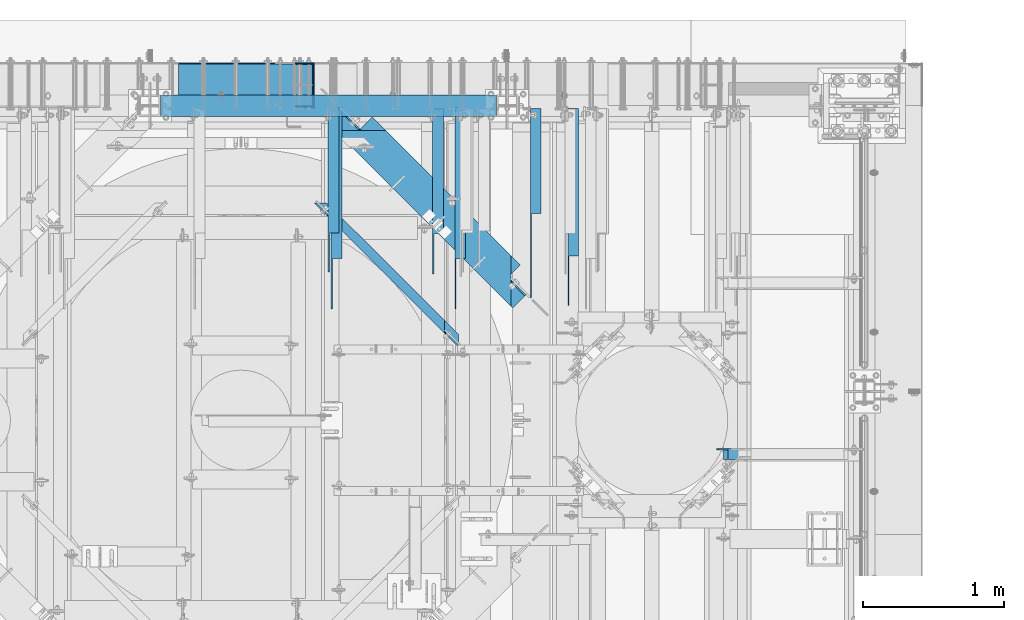
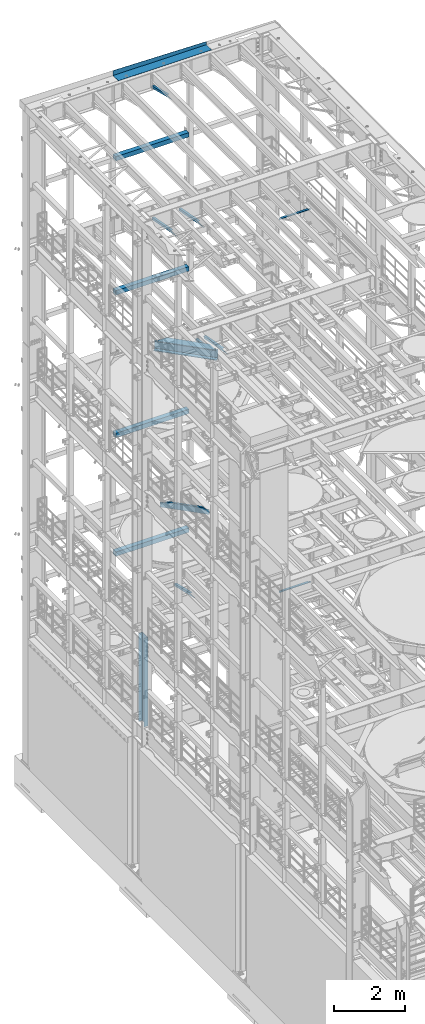
# One storey, part 1064 of 1876: 17 beams, 17 elements without a shape of their own.
"""IFC2X3 building model written with IfcOpenShell, lengths in millimetres."""

from ifc_helpers import new_model, si_unit, frame, origin_with_axes, place, context, subcontext, project, spatial, faceted_brep, material, type_object, element, aggregate, save


model = new_model("IFC2X3")

# Units and contexts
model_context = context("Model", 3, precision=1e-05, world=origin_with_axes())
body_context = subcontext(model_context, "Body", "Model", "MODEL_VIEW")
ifc_project = project(units=[si_unit("LENGTHUNIT", "METRE", prefix="MILLI"), si_unit("AREAUNIT", "SQUARE_METRE"), si_unit("VOLUMEUNIT", "CUBIC_METRE"), si_unit("MASSUNIT", "GRAM", prefix="KILO"), si_unit("TIMEUNIT", "SECOND"), si_unit("PLANEANGLEUNIT", "RADIAN"), si_unit("SOLIDANGLEUNIT", "STERADIAN"), si_unit("THERMODYNAMICTEMPERATUREUNIT", "DEGREE_CELSIUS"), si_unit("LUMINOUSINTENSITYUNIT", "LUMEN")], contexts=[model_context])

# Site, building, storey
site_placement = place(None, origin_with_axes())
site = spatial("IfcSite", under=ifc_project, at=site_placement, CompositionType="ELEMENT")
building_placement = place(site_placement, origin_with_axes())
building = spatial("IfcBuilding", under=site, at=building_placement, Name="Undefined", CompositionType="ELEMENT")
storey_placement = place(building_placement, origin_with_axes())
storey = spatial("IfcBuildingStorey", under=building, at=storey_placement, Name="Undefined", CompositionType="ELEMENT", Elevation=0.0)

# Assembly, beam
assembly_1_placement = place(storey_placement, origin_with_axes())
assembly_1 = element("IfcElementAssembly", 1, at=assembly_1_placement, inside=storey, Name="FRAME", AssemblyPlace="NOTDEFINED", PredefinedType="RIGID_FRAME")
ifc_material_1 = material()
beam_type_1 = type_object("IfcBeamType", Name="HSS6X6X3/8", PredefinedType="NOTDEFINED")
beam_1_placement = place(assembly_1_placement, frame((2546.36120478435, 13716.0, 6330.95), z_axis=(0.0, 1.0, 0.0), x_axis=(1.0, 0.0, 0.0)))
beam_1 = element("IfcBeam", 2, at=beam_1_placement, type_object=beam_type_1, material=ifc_material_1, Name="FRAME", ObjectType="HSS6X6X3/8", context=body_context, shape_type="Brep", body=[
    faceted_brep([(69.8387952156513, 66.6750000000002, -66.6749999999993), (69.8387952156513, -66.6750000000002, -66.6749999999993), (2457.43879521565, -66.6750000000002, -66.6749999999993), (2457.43879521565, 66.6750000000002, -66.6749999999993), (69.8387952156513, -66.6750000000002, 66.6749999999993), (2457.43879521565, -66.6750000000002, 66.6749999999993), (69.8387952156513, 66.6750000000002, 66.6749999999993), (2457.43879521565, 66.6750000000002, 66.6749999999993), (69.8387952156513, 76.1999999999998, -76.2000000000007), (69.8387952156513, 76.1999999999998, 76.2000000000007), (2457.43879521565, 76.1999999999998, 76.2000000000007), (2457.43879521565, 76.1999999999998, -76.2000000000007), (69.8387952156513, -76.1999999999998, 76.2000000000007), (2457.43879521565, -76.1999999999998, 76.2000000000007), (69.8387952156513, -76.1999999999998, -76.2000000000007), (2457.43879521565, -76.1999999999998, -76.2000000000007)], [[[0, 1, 2, 3]], [[1, 4, 5, 2]], [[4, 6, 7, 5]], [[6, 0, 3, 7]], [[8, 9, 10, 11]], [[9, 12, 13, 10]], [[12, 14, 15, 13]], [[14, 8, 11, 15]], [[13, 15, 11, 10], [5, 7, 3, 2]], [[14, 12, 9, 8], [6, 4, 1, 0]]]),
])
aggregate(assembly_1, [beam_1])

assembly_2_placement = place(storey_placement, origin_with_axes())
assembly_2 = element("IfcElementAssembly", 3, at=assembly_2_placement, inside=storey, Name="FRAME", AssemblyPlace="NOTDEFINED", PredefinedType="RIGID_FRAME")
beam_2_placement = place(assembly_2_placement, frame((2546.36120478435, 13716.0, 19958.05), z_axis=(0.0, 1.0, 0.0), x_axis=(1.0, 0.0, 0.0)))
beam_2 = element("IfcBeam", 4, at=beam_2_placement, type_object=beam_type_1, material=ifc_material_1, Name="FRAME", ObjectType="HSS6X6X3/8", context=body_context, shape_type="Brep", body=[
    faceted_brep([(69.8387952156513, 66.6750000000002, -66.6749999999993), (69.8387952156513, -66.6750000000002, -66.6749999999993), (2457.43879521565, -66.6750000000002, -66.6749999999993), (2457.43879521565, 66.6750000000002, -66.6749999999993), (69.8387952156513, -66.6750000000002, 66.6749999999993), (2457.43879521565, -66.6750000000002, 66.6749999999993), (69.8387952156513, 66.6750000000002, 66.6749999999993), (2457.43879521565, 66.6750000000002, 66.6749999999993), (69.8387952156513, 76.1999999999998, -76.2000000000007), (69.8387952156513, 76.1999999999998, 76.2000000000007), (2457.43879521565, 76.1999999999998, 76.2000000000007), (2457.43879521565, 76.1999999999998, -76.2000000000007), (69.8387952156513, -76.1999999999998, 76.2000000000007), (2457.43879521565, -76.1999999999998, 76.2000000000007), (69.8387952156513, -76.1999999999998, -76.2000000000007), (2457.43879521565, -76.1999999999998, -76.2000000000007)], [[[0, 1, 2, 3]], [[1, 4, 5, 2]], [[4, 6, 7, 5]], [[6, 0, 3, 7]], [[8, 9, 10, 11]], [[9, 12, 13, 10]], [[12, 14, 15, 13]], [[14, 8, 11, 15]], [[13, 15, 11, 10], [5, 7, 3, 2]], [[14, 12, 9, 8], [6, 4, 1, 0]]]),
])
aggregate(assembly_2, [beam_2])

assembly_3_placement = place(storey_placement, origin_with_axes())
assembly_3 = element("IfcElementAssembly", 5, at=assembly_3_placement, inside=storey, Name="FRAME", AssemblyPlace="NOTDEFINED", PredefinedType="RIGID_FRAME")
beam_3_placement = place(assembly_3_placement, frame((2546.36120478435, 13716.0, 15335.25), z_axis=(0.0, 1.0, 0.0), x_axis=(1.0, 0.0, 0.0)))
beam_3 = element("IfcBeam", 6, at=beam_3_placement, type_object=beam_type_1, material=ifc_material_1, Name="FRAME", ObjectType="HSS6X6X3/8", context=body_context, shape_type="Brep", body=[
    faceted_brep([(69.8387952156513, 66.6750000000002, -66.6749999999993), (69.8387952156513, -66.6750000000002, -66.6749999999993), (2457.43879521565, -66.6750000000002, -66.6749999999993), (2457.43879521565, 66.6750000000002, -66.6749999999993), (69.8387952156513, -66.6750000000002, 66.6749999999993), (2457.43879521565, -66.6750000000002, 66.6749999999993), (69.8387952156513, 66.6750000000002, 66.6749999999993), (2457.43879521565, 66.6750000000002, 66.6749999999993), (69.8387952156513, 76.1999999999998, -76.2000000000007), (69.8387952156513, 76.1999999999998, 76.2000000000007), (2457.43879521565, 76.1999999999998, 76.2000000000007), (2457.43879521565, 76.1999999999998, -76.2000000000007), (69.8387952156513, -76.1999999999998, 76.2000000000007), (2457.43879521565, -76.1999999999998, 76.2000000000007), (69.8387952156513, -76.1999999999998, -76.2000000000007), (2457.43879521565, -76.1999999999998, -76.2000000000007)], [[[0, 1, 2, 3]], [[1, 4, 5, 2]], [[4, 6, 7, 5]], [[6, 0, 3, 7]], [[8, 9, 10, 11]], [[9, 12, 13, 10]], [[12, 14, 15, 13]], [[14, 8, 11, 15]], [[13, 15, 11, 10], [5, 7, 3, 2]], [[14, 12, 9, 8], [6, 4, 1, 0]]]),
])
aggregate(assembly_3, [beam_3])

assembly_4_placement = place(storey_placement, origin_with_axes())
assembly_4 = element("IfcElementAssembly", 7, at=assembly_4_placement, inside=storey, Name="FRAME", AssemblyPlace="NOTDEFINED", PredefinedType="RIGID_FRAME")
beam_4_placement = place(assembly_4_placement, frame((2546.36120478435, 13716.0, 10420.35), z_axis=(0.0, 1.0, 0.0), x_axis=(1.0, 0.0, 0.0)))
beam_4 = element("IfcBeam", 8, at=beam_4_placement, type_object=beam_type_1, material=ifc_material_1, Name="FRAME", ObjectType="HSS6X6X3/8", context=body_context, shape_type="Brep", body=[
    faceted_brep([(69.8387952156513, 66.6750000000002, -66.6749999999993), (69.8387952156513, -66.6750000000002, -66.6749999999993), (2457.43879521565, -66.6750000000002, -66.6749999999993), (2457.43879521565, 66.6750000000002, -66.6749999999993), (69.8387952156513, -66.6750000000002, 66.6749999999993), (2457.43879521565, -66.6750000000002, 66.6749999999993), (69.8387952156513, 66.6750000000002, 66.6749999999993), (2457.43879521565, 66.6750000000002, 66.6749999999993), (69.8387952156513, 76.1999999999998, -76.2000000000007), (69.8387952156513, 76.1999999999998, 76.2000000000007), (2457.43879521565, 76.1999999999998, 76.2000000000007), (2457.43879521565, 76.1999999999998, -76.2000000000007), (69.8387952156513, -76.1999999999998, 76.2000000000007), (2457.43879521565, -76.1999999999998, 76.2000000000007), (69.8387952156513, -76.1999999999998, -76.2000000000007), (2457.43879521565, -76.1999999999998, -76.2000000000007)], [[[0, 1, 2, 3]], [[1, 4, 5, 2]], [[4, 6, 7, 5]], [[6, 0, 3, 7]], [[8, 9, 10, 11]], [[9, 12, 13, 10]], [[12, 14, 15, 13]], [[14, 8, 11, 15]], [[13, 15, 11, 10], [5, 7, 3, 2]], [[14, 12, 9, 8], [6, 4, 1, 0]]]),
])
aggregate(assembly_4, [beam_4])

assembly_5_placement = place(storey_placement, origin_with_axes())
assembly_5 = element("IfcElementAssembly", 9, at=assembly_5_placement, inside=storey, AssemblyPlace="NOTDEFINED", PredefinedType="RIGID_FRAME")
ifc_material_2 = material(Name="STEEL/A36")
beam_type_2 = type_object("IfcBeamType", Name="L3X3X3/8", PredefinedType="NOTDEFINED")
beam_5_placement = place(assembly_5_placement, frame((4587.875, 12840.0279763324, 4779.41022141264), z_axis=(1.0, 0.0, 0.0), x_axis=(0.0, 0.972828834357878, -0.231525504085172)))
beam_5 = element("IfcBeam", 10, at=beam_5_placement, type_object=beam_type_2, material=ifc_material_2, ObjectType="L3X3X3/8", context=body_context, shape_type="Brep", body=[
    faceted_brep([(0.0, 38.1000000000004, -38.1), (0.0, 38.1000000000004, 38.1), (867.661079933076, 38.1000000002077, 38.1000000000004), (867.661079933076, 38.1000000002077, -38.1000000000004), (-40.0223495126247, 28.5749999999825, 38.1000000000004), (867.661079933077, 28.5750000002117, 38.1000000000004), (-40.0223495126247, 28.5749999999825, -28.5749999999998), (867.661079933077, 28.5750000002117, -28.5749999999998), (-320.178796151862, -38.1000000000677, -28.5749999999998), (867.661079933077, -38.0999999997684, -28.5749999999998), (-320.178796151862, -38.1000000000677, -38.1000000000004), (867.661079933077, -38.0999999997684, -38.1000000000004)], [[[0, 1, 2, 3]], [[1, 4, 5, 2]], [[4, 6, 7, 5]], [[6, 8, 9, 7]], [[8, 10, 11, 9]], [[10, 0, 3, 11]], [[5, 7, 9, 11, 3, 2]], [[10, 8, 6, 4, 1, 0]]]),
])
aggregate(assembly_5, [beam_5])

assembly_6_placement = place(storey_placement, origin_with_axes())
assembly_6 = element("IfcElementAssembly", 11, at=assembly_6_placement, inside=storey, AssemblyPlace="NOTDEFINED", PredefinedType="RIGID_FRAME")
beam_6_placement = place(assembly_6_placement, frame((3844.925, 12840.8509533049, 22213.431722183), z_axis=(1.0, 0.0, 0.0), x_axis=(0.0, 0.970296005691371, -0.241920774923053)))
beam_6 = element("IfcBeam", 12, at=beam_6_placement, type_object=beam_type_2, material=ifc_material_2, ObjectType="L3X3X3/8", context=body_context, shape_type="Brep", body=[
    faceted_brep([(0.0, 38.1000000000004, -38.1), (0.0, 38.1000000000004, 38.1), (871.989692018896, 38.1000000003733, 38.1000000000004), (871.989692018896, 38.1000000003733, -38.1000000000004), (-38.2028763666676, 28.5750000000298, 38.1000000000004), (871.9896920189, 28.5750000003572, 38.1000000000004), (-38.2028763666676, 28.5750000000298, -28.5749999999998), (871.9896920189, 28.5750000003572, -28.5749999999998), (-305.623010913256, -38.1000000001623, -28.5749999999998), (871.989692018928, -38.0999999997366, -28.5749999999998), (-305.623010913256, -38.1000000001623, -38.1000000000004), (871.989692018928, -38.0999999997366, -38.1000000000004)], [[[0, 1, 2, 3]], [[1, 4, 5, 2]], [[4, 6, 7, 5]], [[6, 8, 9, 7]], [[8, 10, 11, 9]], [[10, 0, 3, 11]], [[5, 7, 9, 11, 3, 2]], [[10, 8, 6, 4, 1, 0]]]),
])
aggregate(assembly_6, [beam_6])

assembly_7_placement = place(storey_placement, origin_with_axes())
assembly_7 = element("IfcElementAssembly", 13, at=assembly_7_placement, inside=storey, AssemblyPlace="NOTDEFINED", PredefinedType="RIGID_FRAME")
beam_7_placement = place(assembly_7_placement, frame((5283.19999844433, 12303.2117193861, 12927.6473213718), z_axis=(1.0, 0.0, 0.0), x_axis=(0.0, 0.993801742077241, -0.11116698000864)))
beam_7 = element("IfcBeam", 14, at=beam_7_placement, type_object=beam_type_2, material=ifc_material_2, ObjectType="L3X3X3/8", context=body_context, shape_type="Brep", body=[
    faceted_brep([(1396.57162984495, -38.0999999996911, -28.575), (1396.57162984495, -38.0999999996911, -38.0999999999999), (1396.57162984495, 38.1000000003096, -38.0999999999999), (1396.57162984495, 38.1000000003096, 38.0999999999999), (1396.57162984495, 28.5750000003081, 38.0999999999999), (1396.57162984495, 28.5750000003081, -28.575), (731.882504487789, 38.1000000001623, 38.0999999999999), (646.731665699428, 28.5750000001426, 38.0999999999999), (646.731665699428, 28.5750000001426, -28.575), (50.6757941809065, -38.0999999999876, -28.575), (50.6757941809065, -38.0999999999876, -38.0999999999999), (731.882504487789, 38.1000000001623, -38.0999999999999)], [[[0, 1, 2, 3, 4, 5]], [[4, 3, 6, 7]], [[5, 4, 7, 8]], [[0, 5, 8, 9]], [[1, 0, 9, 10]], [[2, 1, 10, 11]], [[3, 2, 11, 6]], [[10, 9, 8, 7, 6, 11]]]),
])
aggregate(assembly_7, [beam_7])

assembly_8_placement = place(storey_placement, origin_with_axes())
assembly_8 = element("IfcElementAssembly", 15, at=assembly_8_placement, inside=storey, AssemblyPlace="NOTDEFINED", PredefinedType="RIGID_FRAME")
beam_8_placement = place(assembly_8_placement, frame((5549.9, 12498.433225377, 13004.4929171211), z_axis=(1.0, 0.0, 0.0), x_axis=(0.0, 0.981826447972761, -0.189780994994735)))
beam_8 = element("IfcBeam", 16, at=beam_8_placement, type_object=beam_type_2, material=ifc_material_2, ObjectType="L3X3X3/8", context=body_context, shape_type="Brep", body=[
    faceted_brep([(-198.727330666601, -38.0999999999294, -38.1000000000004), (-198.727330666601, -38.0999999999294, -28.5749999999998), (146.213839129041, 28.574999999948, -28.5749999999998), (146.213839129041, 28.574999999948, 38.1000000000004), (195.491149099846, 38.0999999999294, 38.1000000000004), (195.491149099846, 38.0999999999294, -38.1000000000004), (1211.7198728657, 28.5749999995678, 38.1000000000004), (1211.7198728657, 38.0999999995674, 38.1000000000004), (1211.7198728657, 38.0999999995674, -38.1000000000004), (1211.7198728657, -38.1000000004333, -38.1000000000004), (1211.7198728657, -38.1000000004333, -28.5749999999998), (1211.7198728657, 28.5749999995678, -28.5749999999998)], [[[0, 1, 2, 3, 4, 5]], [[4, 3, 6, 7]], [[5, 4, 7, 8]], [[0, 5, 8, 9]], [[1, 0, 9, 10]], [[2, 1, 10, 11]], [[3, 2, 11, 6]], [[10, 9, 8, 7, 6, 11]]]),
])
aggregate(assembly_8, [beam_8])

assembly_9_placement = place(storey_placement, origin_with_axes())
assembly_9 = element("IfcElementAssembly", 17, at=assembly_9_placement, inside=storey, AssemblyPlace="NOTDEFINED", PredefinedType="RIGID_FRAME")
beam_9_placement = place(assembly_9_placement, frame((4746.625, 12478.7701585775, 17678.0584984364), z_axis=(1.0, 0.0, 0.0), x_axis=(0.0, 0.982729825630071, -0.185046182930343)))
beam_9 = element("IfcBeam", 18, at=beam_9_placement, type_object=beam_type_2, material=ifc_material_2, ObjectType="L3X3X3/8", context=body_context, shape_type="Brep", body=[
    faceted_brep([(200.493218531883, 38.099999999944, -38.1000000000004), (200.493218531883, 38.099999999944, 38.1000000000004), (1239.09835784596, 38.0999999993655, 38.1000000000004), (1239.09835784596, 38.0999999993655, -38.1000000000004), (149.908540475497, 28.5749999999571, 38.1000000000004), (1239.09863171315, 28.5749999993495, 38.1000000000004), (149.908540475497, 28.5749999999571, -28.5749999999998), (1239.09863171315, 28.5749999993495, -28.5749999999998), (-204.184205919202, -38.0999999999367, -28.5749999999998), (1239.10054878342, -38.1000000007407, -28.5749999999998), (-204.184205919202, -38.0999999999367, -38.1000000000004), (1239.10054878342, -38.1000000007407, -38.1000000000004)], [[[0, 1, 2, 3]], [[1, 4, 5, 2]], [[4, 6, 7, 5]], [[6, 8, 9, 7]], [[8, 10, 11, 9]], [[10, 0, 3, 11]], [[5, 7, 9, 11, 3, 2]], [[10, 8, 6, 4, 1, 0]]]),
])
aggregate(assembly_9, [beam_9])

assembly_10_placement = place(storey_placement, origin_with_axes())
assembly_10 = element("IfcElementAssembly", 19, at=assembly_10_placement, inside=storey, AssemblyPlace="NOTDEFINED", PredefinedType="RIGID_FRAME")
beam_10_placement = place(assembly_10_placement, frame((3867.15, 12478.7701585775, 17678.0584984364), z_axis=(1.0, 0.0, 0.0), x_axis=(0.0, 0.982729825630071, -0.185046182930343)))
beam_10 = element("IfcBeam", 20, at=beam_10_placement, type_object=beam_type_2, material=ifc_material_2, ObjectType="L3X3X3/8", context=body_context, shape_type="Brep", body=[
    faceted_brep([(200.493218531883, 38.099999999944, -38.1000000000004), (200.493218531883, 38.099999999944, 38.1000000000004), (1239.09835784596, 38.0999999993655, 38.1000000000004), (1239.09835784596, 38.0999999993655, -38.1000000000004), (149.908540475497, 28.5749999999571, 38.1000000000004), (1239.09863171315, 28.5749999993495, 38.1000000000004), (149.908540475497, 28.5749999999571, -28.5749999999998), (1239.09863171315, 28.5749999993495, -28.5749999999998), (-204.184205919202, -38.0999999999367, -28.5749999999998), (1239.10054878342, -38.1000000007407, -28.5749999999998), (-204.184205919202, -38.0999999999367, -38.1000000000004), (1239.10054878342, -38.1000000007407, -38.1000000000004)], [[[0, 1, 2, 3]], [[1, 4, 5, 2]], [[4, 6, 7, 5]], [[6, 8, 9, 7]], [[8, 10, 11, 9]], [[10, 0, 3, 11]], [[5, 7, 9, 11, 3, 2]], [[10, 8, 6, 4, 1, 0]]]),
])
aggregate(assembly_10, [beam_10])

assembly_11_placement = place(storey_placement, origin_with_axes())
assembly_11 = element("IfcElementAssembly", 21, at=assembly_11_placement, inside=storey, Name="ANGLE", AssemblyPlace="NOTDEFINED", PredefinedType="RIGID_FRAME")
beam_11_placement = place(assembly_11_placement, frame((6565.89999988253, 11239.5, 17945.1), z_axis=(0.0, -1.0, 0.0), x_axis=(1.0, 0.0, 0.0)))
beam_11 = element("IfcBeam", 22, at=beam_11_placement, type_object=beam_type_2, material=ifc_material_2, Name="ANGLE", ObjectType="L3X3X3/8", context=body_context, shape_type="Brep", body=[
    faceted_brep([(52.3875000813496, 38.0999999999985, 38.0999999999858), (52.3875000813123, 28.5750001907327, 38.0999999999858), (938.213001286278, 28.5750000000007, 38.0999999999999), (938.213001286278, 38.0999999999985, 38.0999999999999), (52.3875051486311, 28.5750000000007, -28.5750000000144), (938.213000419482, 28.5750000000007, -28.5749999999998), (1015.20625603472, 12.6999992370475, -28.5749999999998), (1015.20625591089, 12.6999992370475, -38.0999999999999), (938.213000295654, 12.6999992370475, -38.0999999999999), (938.213000419482, 12.6999992370475, -28.5749999999998), (938.213000295654, 38.0999999999985, -38.0999999999999), (52.3875058725371, 38.0999999999985, -38.1000000000149), (52.3875058725339, 28.5750001907327, -38.1000000000149), (15.8749999382144, 28.5750001907327, -38.0999999999999), (15.8749936676099, 28.5749999999989, -28.5750000000007), (3.17500012894925, 15.8750003814675, -38.0999999999999), (3.17500032897624, 15.8750003814675, -28.5749999999998), (3.17499999075153, -38.0999999999985, -28.5749999999998), (3.17499999075153, -38.0999999999985, -38.0999999999999), (1046.95625011747, -38.0999999999985, -28.5749999999998), (1046.95625603472, -19.0500007629525, -28.5749999999998), (1046.95625591089, -19.0500007629525, -38.0999999999999), (1046.95625011747, -38.0999999999985, -38.0999999999999)], [[[0, 1, 2, 3]], [[1, 4, 5, 2]], [[6, 7, 8, 9]], [[2, 5, 9, 8, 10, 3]], [[11, 0, 3, 10]], [[1, 0, 11, 12, 4]], [[4, 12, 13, 14]], [[14, 13, 15, 16]], [[17, 16, 15, 18]], [[6, 9, 5, 4, 14, 16, 17, 19, 20]], [[7, 6, 20, 21]], [[18, 15, 13, 12, 11, 10, 8, 7, 21, 22]], [[17, 18, 22, 19]], [[21, 20, 19, 22]]]),
])
aggregate(assembly_11, [beam_11])

assembly_12_placement = place(storey_placement, origin_with_axes())
assembly_12 = element("IfcElementAssembly", 23, at=assembly_12_placement, inside=storey, Name="ANGLE", AssemblyPlace="NOTDEFINED", PredefinedType="RIGID_FRAME")
beam_12_placement = place(assembly_12_placement, frame((6565.9, 11239.5, 5092.7), z_axis=(0.0, -1.0, 0.0), x_axis=(1.0, 0.0, 0.0)))
beam_12 = element("IfcBeam", 24, at=beam_12_placement, type_object=beam_type_2, material=ifc_material_2, Name="ANGLE", ObjectType="L3X3X3/8", context=body_context, shape_type="Brep", body=[
    faceted_brep([(938.213000419482, 28.5750000000007, -28.5749999999998), (938.213001286278, 28.5750000000007, 38.0999999999999), (84.137014014791, 28.5749999999998, 38.1000000000258), (84.1370001605219, 28.5749999999998, -28.5750000000007), (938.213001286278, 38.0999999999985, 38.0999999999999), (84.136999759924, 38.0999999999985, 38.0999999999999), (15.8750004498515, 25.4000000000005, -28.5750000000007), (15.8750002879233, 25.4000000000005, -38.1000000000004), (3.17500047865815, 12.7000001907354, -38.1000000000004), (3.1750006405864, 12.7000001907354, -28.5750000000007), (84.1369986264262, 25.4000000000005, -28.5750000000007), (84.136998464498, 25.4000000000005, -38.1000000000004), (84.1369984645207, 38.0999999999985, -38.0999999999999), (938.213000295654, 38.0999999999985, -38.0999999999999), (938.213000419482, 12.6999992370475, -28.5749999999998), (938.213000295654, 12.6999992370475, -38.0999999999999), (1015.20625603472, 12.6999992370475, -28.5749999999998), (1015.20625591089, 12.6999992370475, -38.0999999999999), (1046.95625603472, -19.0500007629525, -28.5749999999998), (1046.95625591089, -19.0500007629525, -38.0999999999999), (1046.95625011747, -38.0999999999985, -28.5749999999998), (1046.95625011747, -38.0999999999985, -38.0999999999999), (3.17499999075153, -38.0999999999985, -28.5749999999998), (3.17499999075153, -38.0999999999985, -38.0999999999999), (3.17500047865815, -1.52587836055318e-06, -38.1000000000004), (3.1750006405864, -1.52587836055318e-06, -28.5750000000007)], [[[0, 1, 2, 3]], [[1, 4, 5, 2]], [[6, 7, 8, 9]], [[10, 11, 7, 6]], [[2, 5, 12, 11, 10, 3]], [[4, 13, 12, 5]], [[1, 0, 14, 15, 13, 4]], [[16, 17, 15, 14]], [[17, 16, 18, 19]], [[19, 18, 20, 21]], [[22, 23, 21, 20]], [[8, 7, 11, 12, 13, 15, 17, 19, 21, 23, 24]], [[9, 8, 24, 25]], [[20, 18, 16, 14, 0, 3, 10, 6, 9, 25, 22]], [[24, 23, 22, 25]]]),
])
aggregate(assembly_12, [beam_12])

assembly_13_placement = place(storey_placement, origin_with_axes())
assembly_13 = element("IfcElementAssembly", 25, at=assembly_13_placement, inside=storey, Name="BENT PLATE", AssemblyPlace="NOTDEFINED", PredefinedType="RIGID_FRAME")
beam_type_3 = type_object("IfcBeamType", PredefinedType="NOTDEFINED")
beam_13_placement = place(assembly_13_placement, frame((4267.2, 13715.9999771422, 22558.3750000001), z_axis=(1.0, 0.0, 0.0), x_axis=(0.0, 0.999999999968684, -7.91400000071008e-06)))
beam_13 = element("IfcBeam", 26, at=beam_13_placement, type_object=beam_type_3, material=ifc_material_2, Name="BENT PLATE", context=body_context, shape_type="Brep", body=[
    faceted_brep([(-9.88620740827173e-10, 3.17500000000291, -1524.0), (-9.88620740827173e-10, 3.17500000000291, 1524.0), (298.449951181141, 3.17499990714714, 1524.0), (298.449951181141, 3.17499990714714, -1524.0), (9.877112461254e-10, -3.17499999999563, -1524.0), (9.877112461254e-10, -3.17499999999563, 1524.0), (304.799984389467, -3.1750000948341, -1524.0), (304.799984389467, -3.1750000948341, 1524.0), (304.799391923081, 110.115017685181, 1524.0), (298.449391923228, 110.114971971532, 1524.0), (298.449059744577, 173.63338633149, -1524.0), (304.799059744493, 173.633419539721, -1524.0)], [[[0, 1, 2, 3]], [[4, 5, 1, 0]], [[5, 4, 6, 7]], [[2, 1, 5, 7, 8, 9]], [[3, 2, 9, 10]], [[6, 4, 0, 3, 10, 11]], [[7, 6, 11, 8]], [[10, 9, 8, 11]]]),
])
aggregate(assembly_13, [beam_13])

assembly_14_placement = place(storey_placement, origin_with_axes())
assembly_14 = element("IfcElementAssembly", 27, at=assembly_14_placement, inside=storey, Name="BEAM", AssemblyPlace="NOTDEFINED", PredefinedType="RIGID_FRAME")
beam_type_4 = type_object("IfcBeamType", Name="C8X18.75", PredefinedType="NOTDEFINED")
beam_14_placement = place(assembly_14_placement, frame((4984.17492767281, 11795.4807496624, 8051.8), z_axis=(0.0, 0.0, 1.0), x_axis=(-0.707305809668415, 0.706907696668602, 0.0)))
beam_14 = element("IfcBeam", 28, at=beam_14_placement, type_object=beam_type_4, material=ifc_material_2, Name="BEAM", ObjectType="C8X18.75", context=body_context, shape_type="Brep", body=[
    faceted_brep([(386.661601394823, -31.7500000001164, -101.6), (323.197342901677, 31.7499999999054, -101.6), (1772.80211504471, 31.7499999994725, -101.6), (1709.26635340903, -31.7500000005111, -101.6), (386.661601394823, -31.7500000001164, -97.3645500000002), (1709.26635340903, -31.7500000005111, -97.3645500000002), (335.890194600306, 19.049999999901, -88.9012700000003), (1760.09496271758, 19.0499999994754, -88.9012700000003), (335.890194600306, 19.049999999901, 73.0249999999996), (323.197342901677, 31.7499999999054, 73.0249999999996), (455.967320369644, 19.0499999998647, 73.0249999999996), (443.274468671014, 31.749999999869, 73.0249999999996), (462.838576694156, 19.0499999998628, 73.9917299225872), (450.145724995527, 31.7499999998672, 73.9917299225872), (468.663746531355, 19.049999999861, 76.7447438230656), (455.970894832727, 31.7499999998672, 76.7447438230656), (472.556000578824, 19.049999999861, 80.8649202912193), (459.863148880195, 31.7499999998654, 80.8649202912193), (473.922778441206, 19.0499999998592, 85.7249998092648), (461.229926742577, 31.7499999998654, 85.7249998092648), (524.694185235578, -31.7500000001583, 101.6), (461.229926742471, 31.7499999998654, 101.6), (473.922778441093, 19.049999999861, 88.9012700000003), (524.694185235578, -31.7500000001583, 97.3645500000002), (1621.98464234188, 19.0499999995172, 88.9012700000003), (1571.15603303337, -31.7500000004693, 97.3645500000002), (1571.15603303337, -31.7500000004693, 101.6), (1634.691794669, 31.7499999995143, 101.6), (1634.69179466905, 31.7499999995143, 85.7249998092657), (1636.05934226705, 31.7499999995125, 80.8649202912202), (1639.95378833611, 31.7499999995125, 76.7447438230665), (1645.78223876546, 31.7499999995107, 73.9917299225881), (1652.65736481226, 31.7499999995089, 73.0250000000005), (1772.80211504471, 31.7499999994725, 73.0250000000005), (1760.09496271758, 19.0499999994754, 73.0250000000005), (1633.07508643833, 19.0499999995136, 73.9917299225881), (1627.24663600898, 19.0499999995154, 76.7447438230665), (1623.35218993992, 19.0499999995172, 80.8649202912202), (1621.98464234191, 19.0499999995172, 85.7249998092657), (1639.95021248512, 19.0499999995118, 73.0250000000005)], [[[0, 1, 2, 3]], [[4, 0, 3, 5]], [[6, 4, 5, 7]], [[1, 0, 4, 6, 8, 9]], [[10, 11, 9, 8]], [[12, 13, 11, 10]], [[14, 15, 13, 12]], [[16, 17, 15, 14]], [[18, 19, 17, 16]], [[20, 21, 19, 18, 22, 23]], [[23, 22, 24, 25]], [[20, 23, 25, 26]], [[21, 20, 26, 27]], [[2, 1, 9, 11, 13, 15, 17, 19, 21, 27, 28, 29, 30, 31, 32, 33]], [[7, 5, 3, 2, 33, 34]], [[35, 36, 37, 38, 24, 22, 18, 16, 14, 12, 10, 8, 6, 7, 34, 39]], [[33, 32, 39, 34]], [[31, 35, 39, 32]], [[30, 36, 35, 31]], [[29, 37, 36, 30]], [[28, 38, 37, 29]], [[27, 26, 25, 24, 38, 28]]]),
])
aggregate(assembly_14, [beam_14])

assembly_15_placement = place(storey_placement, origin_with_axes())
assembly_15 = element("IfcElementAssembly", 29, at=assembly_15_placement, inside=storey, Name="BEAM", AssemblyPlace="NOTDEFINED", PredefinedType="REINFORCEMENT_UNIT")
ifc_material_3 = material(Name="CONCRETE/5000")
beam_type_5 = type_object("IfcBeamType", PredefinedType="NOTDEFINED")
beam_15_placement = place(assembly_15_placement, frame((3575.04950115648, 13713.6189938963, 1524.0), z_axis=(0.0, 0.0, 1.0), x_axis=(1.0, 0.0, 0.0)))
beam_15 = element("IfcBeam", 30, at=beam_15_placement, type_object=beam_type_5, material=ifc_material_3, Name="BEAM", context=body_context, shape_type="Brep", body=[
    faceted_brep([(1.60071067512035e-10, -2.38100000000122, -1524.0), (1.60071067512035e-10, -2.38100000000122, 1524.0), (-1.60071067512035e-10, 2.38099999999758, 1524.0), (-1.60071067512035e-10, 2.38099999999758, -1524.0), (122.237998962702, 2.38099999183942, 1524.0), (122.237998962702, 2.38099999183942, -1524.0), (126.999998724603, -2.38100000847589, -1524.0), (126.999998724603, -2.38100000847589, 1524.0), (122.238013726454, 297.655987784639, 1524.0), (122.238013726454, 297.655987784639, -1524.0), (127.000013964554, 302.417987546543, -1524.0), (127.000013964554, 302.417987546543, 1524.0), (1.47643368109129e-05, 297.655993896484, 1524.0), (1.47643368109129e-05, 297.655993896484, -1524.0), (1.50024361573742e-05, 302.417993896484, 1524.0), (1.50024361573742e-05, 302.417993896484, -1524.0)], [[[0, 1, 2, 3]], [[3, 2, 4, 5]], [[1, 0, 6, 7]], [[5, 4, 8, 9]], [[7, 6, 10, 11]], [[9, 8, 12, 13]], [[8, 4, 2, 1, 7, 11, 14, 12]], [[11, 10, 15, 14]], [[10, 6, 0, 3, 5, 9, 13, 15]], [[14, 15, 13, 12]]]),
])
aggregate(assembly_15, [beam_15])

assembly_16_placement = place(storey_placement, origin_with_axes())
assembly_16 = element("IfcElementAssembly", 31, at=assembly_16_placement, inside=storey, Name="BENT PLATE", AssemblyPlace="NOTDEFINED", PredefinedType="RIGID_FRAME")
beam_type_6 = type_object("IfcBeamType", PredefinedType="NOTDEFINED")
beam_16_placement = place(assembly_16_placement, frame((3575.04950127537, 13706.4754938963, 1524.0), z_axis=(0.0, 0.0, 1.0), x_axis=(1.0, 0.0, 0.0)))
beam_16 = element("IfcBeam", 32, at=beam_16_placement, type_object=beam_type_6, material=ifc_material_2, Name="BENT PLATE", context=body_context, shape_type="Brep", body=[
    faceted_brep([(9.877112461254e-10, -3.17499999999563, -1524.0), (9.877112461254e-10, -3.17499999999563, 1524.0), (-9.88620740827173e-10, 3.17500000000291, 1524.0), (-9.88620740827173e-10, 3.17500000000291, -1524.0), (126.999999999999, 3.17499999999927, 1524.0), (126.999999999999, 3.17499999999927, -1524.0), (133.349999999999, -3.17499999999927, -1524.0), (133.349999999999, -3.17499999999927, 1524.0), (126.999999999999, 309.561474609374, 1524.0), (126.999999999999, 309.561474609374, -1524.0), (133.349999999999, 315.911474609373, -1524.0), (133.349999999999, 315.911474609373, 1524.0), (-2.37773747358005e-07, 309.561474609374, 1524.0), (-2.37773747358005e-07, 309.561474609374, -1524.0), (-2.37773747358005e-07, 315.911474609373, 1524.0), (-2.37773747358005e-07, 315.911474609373, -1524.0)], [[[0, 1, 2, 3]], [[3, 2, 4, 5]], [[1, 0, 6, 7]], [[5, 4, 8, 9]], [[7, 6, 10, 11]], [[9, 8, 12, 13]], [[8, 4, 2, 1, 7, 11, 14, 12]], [[11, 10, 15, 14]], [[10, 6, 0, 3, 5, 9, 13, 15]], [[14, 15, 13, 12]]]),
])
aggregate(assembly_16, [beam_16])

assembly_17_placement = place(storey_placement, origin_with_axes())
assembly_17 = element("IfcElementAssembly", 33, at=assembly_17_placement, inside=storey, Name="BEAM", AssemblyPlace="NOTDEFINED", PredefinedType="RIGID_FRAME")
ifc_material_4 = material(Name="STEEL/A992")
beam_type_7 = type_object("IfcBeamType", Name="W14X68", PredefinedType="NOTDEFINED")
beam_17_placement = place(assembly_17_placement, frame((3862.34076683708, 13715.9532683632, 13131.8), z_axis=(0.0, 0.0, 1.0), x_axis=(0.707106781186547, -0.707106781186548, 0.0)))
beam_17 = element("IfcBeam", 34, at=beam_17_placement, type_object=beam_type_7, material=ifc_material_4, Name="BEAM", ObjectType="W14X68", context=body_context, shape_type="Brep", body=[
    faceted_brep([(1726.91685883749, 5.55618586094533, -158.75000000468), (1726.91685883749, 5.55621965513456, -177.799999999999), (1726.9168588375, 127.000000000022, -177.799999999999), (1726.9168588375, 127.000000000022, -158.75), (1906.89605320592, 5.55624744201668, -158.750000000178), (1906.89605320587, 5.55621965513637, -177.799999999999), (1734.06063927637, 5.55618555239926, -158.7500000045), (122.136018845285, -127.000000000022, 158.75), (243.579768845306, -5.55625000000146, 158.75), (1765.75253604926, -5.55625000000146, 158.75), (1887.19628604928, -127.000000000022, 158.75), (1783.71304802167, -5.55625000000146, 133.35), (1772.60032734491, 5.55647067675091, 133.35), (1765.72713698528, 5.55647066775236, 134.316729922588), (1776.83985765303, -5.55624999999964, 134.316729922588), (1759.90032547809, 5.55647273430441, 137.069743823065), (1771.0130482124, -5.55625000000146, 137.069743823065), (1754.63982183836, 5.5564664066751, 137.0), (1765.75253824504, -5.55625000000146, 137.0), (1765.75253604926, -5.55625000000146, 146.049999809266), (1754.63980448173, 5.55648156752795, 146.049999809266), (254.692268845307, 5.55624999999964, 158.75), (376.136018845327, 127.00000000002, 158.75), (1633.19628604924, 127.000000000022, 158.75), (1754.64003604926, 5.55625000000146, 158.75), (376.136018845327, 127.00000000002, 177.799999999999), (122.136018845285, -127.000000000022, 177.799999999999), (1887.19628604928, -127.000000000022, 177.799999999999), (1633.19628604924, 127.000000000022, 177.799999999999), (254.692342991324, 5.55632414601678, 126.999999809264), (243.579768845306, -5.55625000000146, 126.999999809264), (253.325175341757, 5.55631906412964, 122.139920291218), (242.212606277628, -5.55624999999964, 122.139920291218), (249.431821438081, 5.55631475590963, 118.019743823064), (238.319256682171, -5.55625000000146, 118.019743823064), (243.605009118784, 5.55631187724975, 115.266729922587), (232.492447241533, -5.55625000000146, 115.266729922587), (239.759231637656, 5.55631131164591, 114.725812616294), (236.7318177393, 5.55631086640096, 114.299999999999), (225.6192568729, -5.55624999999964, 114.299999999999), (59.7799029577418, 5.55625236178275, 114.299999999999), (59.7798637555497, -5.55625000000146, 114.299999999999), (239.759231637665, 127.000000000022, -158.75), (239.759231637665, 127.000000000022, -177.799999999999), (239.759231637663, 5.55625009274263, -177.799999999999), (239.759231637663, 5.55625009274263, -158.750000041869), (59.7799085014713, 5.55691643295904, -177.799999999999), (59.7799084978269, 5.5555860190525, -158.750000046371), (59.7798688347284, -5.55558668486628, -177.799999999999), (59.779435331664, -127.000000000022, -177.799999999999), (59.779435331664, -127.000000000022, -158.75), (59.7798637555497, -5.55625000000146, -158.75), (59.7798637555497, -5.55625000000146, -139.709257427639), (1906.89584231022, -127.00000000002, -177.799999999999), (1906.89584231022, -127.00000000002, -158.75), (1906.89603552604, -5.55625000000146, -158.75), (1906.89603552604, -5.55625000000146, 133.35), (1906.89605320594, 5.5562611455025, 133.35), (1906.89605320594, 5.55626103126633, 130.915006484982)], [[[0, 1, 2, 3]], [[4, 5, 1, 0, 6]], [[7, 8, 9, 10]], [[11, 12, 13, 14]], [[14, 13, 15, 16]], [[16, 15, 17, 18]], [[19, 18, 17, 20]], [[21, 22, 23, 24]], [[25, 26, 27, 28]], [[22, 25, 28, 23]], [[27, 10, 9, 19, 20, 24, 23, 28]], [[26, 7, 10, 27]], [[25, 22, 21, 29, 30, 8, 7, 26]], [[31, 32, 30, 29]], [[33, 34, 32, 31]], [[35, 36, 34, 33]], [[37, 38, 39, 36, 35]], [[39, 38, 40, 41]], [[42, 43, 44, 45]], [[45, 44, 46, 47]], [[48, 49, 50, 51, 52, 41, 40, 47, 46]], [[50, 49, 53, 54]], [[51, 50, 54, 55]], [[11, 14, 16, 18, 19, 9, 8, 30, 32, 34, 36, 39, 41, 52, 51, 55, 56]], [[12, 11, 56, 57]], [[4, 6, 0, 45, 47, 40, 38, 37, 35, 33, 31, 29, 21, 24, 20, 17, 15, 13, 12, 57, 58]], [[42, 45, 0, 3]], [[43, 42, 3, 2]], [[53, 49, 48, 46, 44, 43, 2, 1, 5]], [[58, 57, 56, 55, 54, 53, 5, 4]]]),
])
aggregate(assembly_17, [beam_17])

save(model, "model.ifc")
